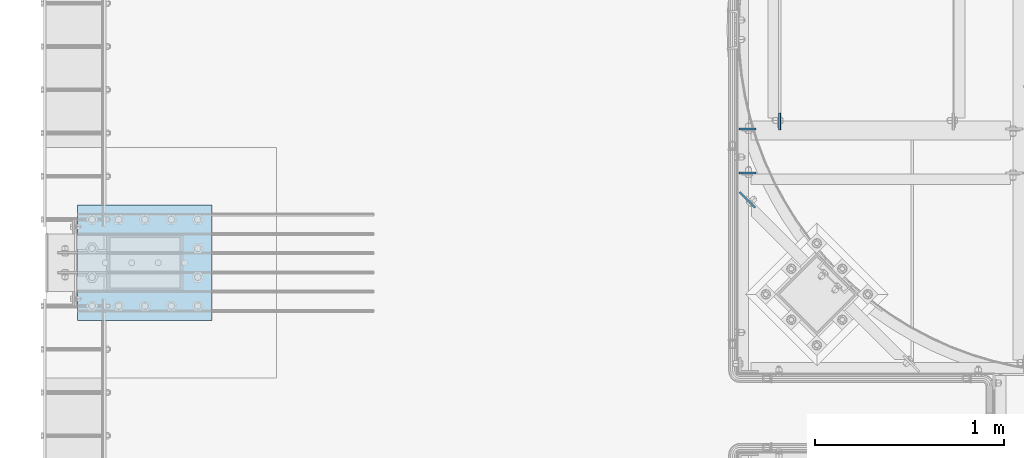
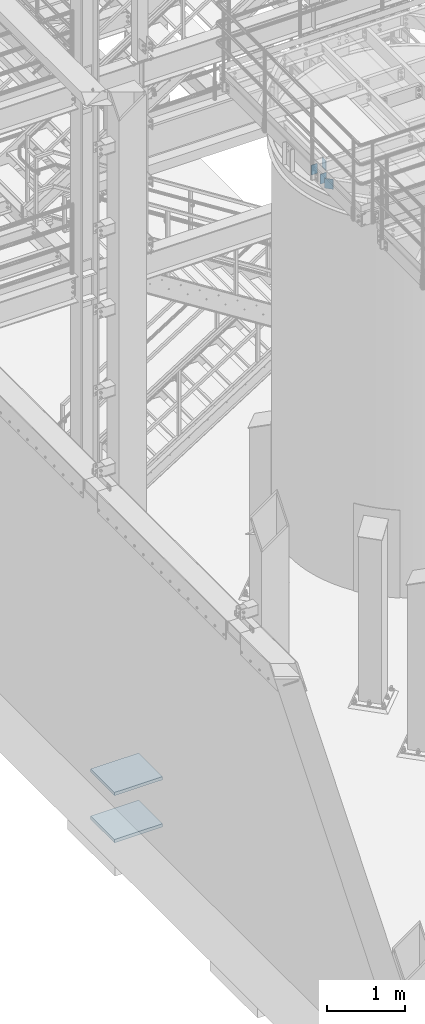
# One storey, part 1416 of 1876: 6 plates, 3 elements without a shape of their own.
"""IFC2X3 building model written with IfcOpenShell, lengths in millimetres."""

from ifc_helpers import new_model, si_unit, frame, origin_with_axes, place, context, subcontext, project, spatial, faceted_brep, material, type_object, element, aggregate, save


model = new_model("IFC2X3")

# Units and contexts
model_context = context("Model", 3, precision=1e-05, world=origin_with_axes())
body_context = subcontext(model_context, "Body", "Model", "MODEL_VIEW")
ifc_project = project(units=[si_unit("LENGTHUNIT", "METRE", prefix="MILLI"), si_unit("AREAUNIT", "SQUARE_METRE"), si_unit("VOLUMEUNIT", "CUBIC_METRE"), si_unit("MASSUNIT", "GRAM", prefix="KILO"), si_unit("TIMEUNIT", "SECOND"), si_unit("PLANEANGLEUNIT", "RADIAN"), si_unit("SOLIDANGLEUNIT", "STERADIAN"), si_unit("THERMODYNAMICTEMPERATUREUNIT", "DEGREE_CELSIUS"), si_unit("LUMINOUSINTENSITYUNIT", "LUMEN")], contexts=[model_context])

# Site, building, storey
site_placement = place(None, origin_with_axes())
site = spatial("IfcSite", under=ifc_project, at=site_placement, CompositionType="ELEMENT")
building_placement = place(site_placement, origin_with_axes())
building = spatial("IfcBuilding", under=site, at=building_placement, Name="Undefined", CompositionType="ELEMENT")
storey_placement = place(building_placement, origin_with_axes())
storey = spatial("IfcBuildingStorey", under=building, at=storey_placement, Name="Undefined", CompositionType="ELEMENT", Elevation=0.0)

# Assembly, plate
assembly_1_placement = place(storey_placement, origin_with_axes())
assembly_1 = element("IfcElementAssembly", 1, at=assembly_1_placement, inside=storey, Name="BEAM", AssemblyPlace="NOTDEFINED", PredefinedType="RIGID_FRAME")
ifc_material_1 = material(Name="STEEL/A36")
plate_type_1 = type_object("IfcPlateType", PredefinedType="NOTDEFINED")
plate_1_placement = place(assembly_1_placement, frame((3586.16583884985, -10067.8893554687, 7972.425), z_axis=(0.0, 1.0, 0.0), x_axis=(0.0, 0.0, -1.0)))
plate_1 = element("IfcPlate", 2, at=plate_1_placement, type_object=plate_type_1, material=ifc_material_1, Name="PLATE", context=body_context, shape_type="Brep", body=[
    faceted_brep([(0.0, -4.76249999999982, 0.0), (0.0, -4.76249999999982, 88.9000015258789), (0.0, 4.76249999999982, 88.9000015258789), (0.0, 4.76249999999982, 0.0), (152.399993896484, -4.76249999999982, 88.9000015258789), (152.399993896484, 4.76249999999982, 88.9000015258789), (152.399993896484, -4.76249999999982, 0.0), (152.399993896484, 4.76249999999982, 0.0)], [[[0, 1, 2, 3]], [[1, 4, 5, 2]], [[4, 6, 7, 5]], [[6, 0, 3, 7]], [[5, 7, 3, 2]], [[6, 4, 1, 0]]]),
])
aggregate(assembly_1, [plate_1])

# Assembly, plates
assembly_2_placement = place(storey_placement, origin_with_axes())
assembly_2 = element("IfcElementAssembly", 3, at=assembly_2_placement, inside=storey, Name="BEAM", AssemblyPlace="NOTDEFINED", PredefinedType="RIGID_FRAME")
plate_2_placement = place(assembly_2_placement, frame((3371.85333884985, -10063.1268554687, 7972.425), z_axis=(1.0, 0.0, 0.0), x_axis=(0.0, 0.0, -1.0)))
plate_2 = element("IfcPlate", 4, at=plate_2_placement, type_object=plate_type_1, material=ifc_material_1, Name="PLATE", context=body_context, shape_type="Brep", body=[
    faceted_brep([(0.0, -4.76249999999982, 0.0), (0.0, -4.76249999999982, 88.9000015258789), (0.0, 4.76249999999982, 88.9000015258789), (0.0, 4.76249999999982, 0.0), (152.399993896484, -4.76249999999982, 88.9000015258789), (152.399993896484, 4.76249999999982, 88.9000015258789), (152.399993896484, -4.76249999999982, 0.0), (152.399993896484, 4.76249999999982, 0.0)], [[[0, 1, 2, 3]], [[1, 4, 5, 2]], [[4, 6, 7, 5]], [[6, 0, 3, 7]], [[5, 7, 3, 2]], [[6, 4, 1, 0]]]),
])
plate_3_placement = place(assembly_2_placement, frame((3371.85333884985, -10294.9018554687, 7972.425), z_axis=(1.0, 0.0, 0.0), x_axis=(0.0, 0.0, -1.0)))
plate_3 = element("IfcPlate", 5, at=plate_3_placement, type_object=plate_type_1, material=ifc_material_1, Name="PLATE", context=body_context, shape_type="Brep", body=[
    faceted_brep([(0.0, -4.76249999999982, 0.0), (0.0, -4.76249999999982, 88.9000015258789), (0.0, 4.76249999999982, 88.9000015258789), (0.0, 4.76249999999982, 0.0), (152.399993896484, -4.76249999999982, 88.9000015258789), (152.399993896484, 4.76249999999982, 88.9000015258789), (152.399993896484, -4.76249999999982, 0.0), (152.399993896484, 4.76249999999982, 0.0)], [[[0, 1, 2, 3]], [[1, 4, 5, 2]], [[4, 6, 7, 5]], [[6, 0, 3, 7]], [[5, 7, 3, 2]], [[6, 4, 1, 0]]]),
])
plate_type_2 = type_object("IfcPlateType", PredefinedType="NOTDEFINED")
plate_4_placement = place(assembly_2_placement, frame((3375.22093489526, -10396.1380257263, 7972.425), z_axis=(0.707106781186547, -0.707106781186548, 0.0), x_axis=(0.0, 0.0, -1.0)))
plate_4 = element("IfcPlate", 6, at=plate_4_placement, type_object=plate_type_2, material=ifc_material_1, Name="PLATE", context=body_context, shape_type="Brep", body=[
    faceted_brep([(0.0, -4.76249999999982, 0.0), (0.0, -4.76249999999891, 116.385513305684), (0.0, 4.76250000000255, 116.385513305684), (0.0, 4.76249999999982, 0.0), (152.399993896484, -4.76249999999891, 116.385513305684), (152.399993896484, 4.76250000000255, 116.385513305684), (152.399993896484, -4.76249999999982, 0.0), (152.399993896484, 4.76249999999982, 0.0)], [[[0, 1, 2, 3]], [[1, 4, 5, 2]], [[4, 6, 7, 5]], [[6, 0, 3, 7]], [[5, 7, 3, 2]], [[6, 4, 1, 0]]]),
])
aggregate(assembly_2, [plate_4, plate_2, plate_3])

assembly_3_placement = place(storey_placement, origin_with_axes())
assembly_3 = element("IfcElementAssembly", 7, at=assembly_3_placement, inside=storey, Name="PLATE", AssemblyPlace="NOTDEFINED", PredefinedType="RIGID_FRAME")
ifc_material_2 = material(Name="STEEL/A572-GR.50")
plate_type_3 = type_object("IfcPlateType", PredefinedType="NOTDEFINED")
plate_5_placement = place(assembly_3_placement, frame((587.375, -10464.8, -762.0), z_axis=(0.0, -1.0, 0.0), x_axis=(-1.0, 0.0, 0.0)))
plate_5 = element("IfcPlate", 8, at=plate_5_placement, type_object=plate_type_3, material=ifc_material_2, Name="PLATE", context=body_context, shape_type="Brep", body=[
    faceted_brep([(0.0, -25.3999996185375, 0.0), (0.0, -25.4, 609.599975585938), (0.0, 25.4, 609.599975585938), (0.0, 25.3999996185339, 9.09494701772928e-13), (711.200012207031, -25.4, 609.599975585938), (711.200012207031, 25.4, 609.599975585938), (711.200012207031, -25.4, 0.0), (711.200012207031, 25.4, 0.0)], [[[0, 1, 2, 3]], [[1, 4, 5, 2]], [[4, 6, 7, 5]], [[6, 0, 3, 7]], [[5, 7, 3, 2]], [[6, 4, 1, 0]]]),
])
plate_6_placement = place(assembly_3_placement, frame((587.375, -10464.8, -25.4), z_axis=(0.0, -1.0, 0.0), x_axis=(-1.0, 0.0, 0.0)))
plate_6 = element("IfcPlate", 9, at=plate_6_placement, type_object=plate_type_3, material=ifc_material_2, Name="PLATE", context=body_context, shape_type="Brep", body=[
    faceted_brep([(0.0, -25.3999996185375, 0.0), (0.0, -25.4, 609.599975585938), (0.0, 25.4, 609.599975585938), (0.0, 25.3999996185339, 9.09494701772928e-13), (711.200012207031, -25.4, 609.599975585938), (711.200012207031, 25.4, 609.599975585938), (711.200012207031, -25.4, 0.0), (711.200012207031, 25.4, 0.0)], [[[0, 1, 2, 3]], [[1, 4, 5, 2]], [[4, 6, 7, 5]], [[6, 0, 3, 7]], [[5, 7, 3, 2]], [[6, 4, 1, 0]]]),
])
aggregate(assembly_3, [plate_5, plate_6])

save(model, "model.ifc")
